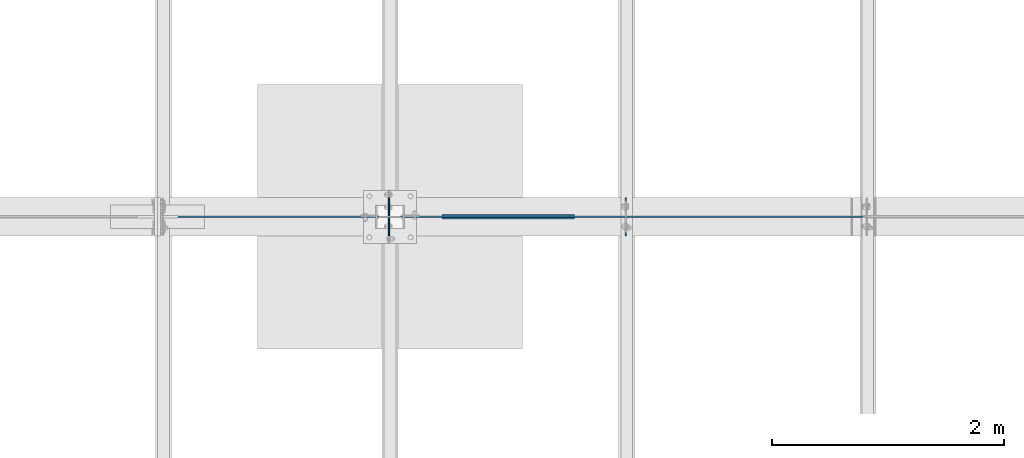
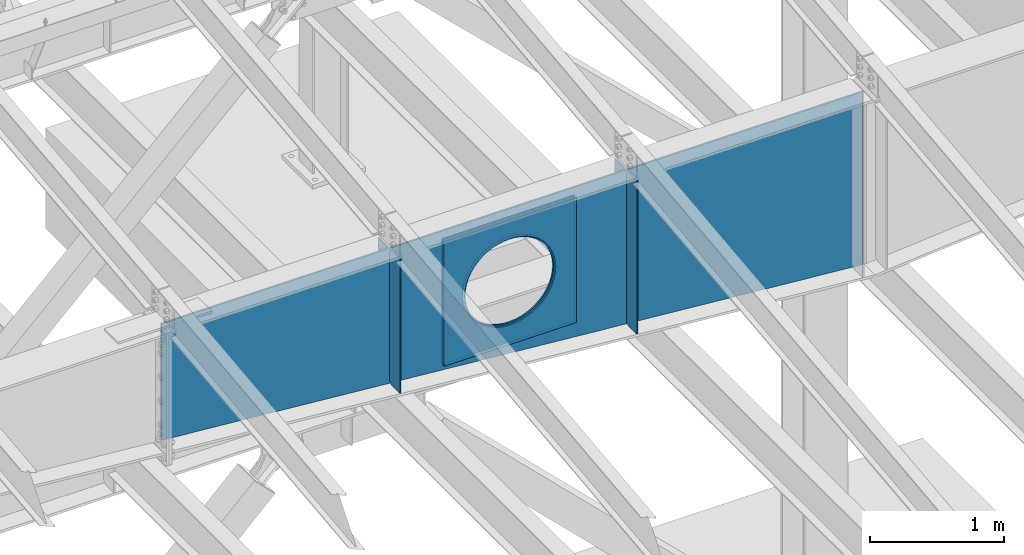
# One storey, part 972 of 1179: 7 plates, 1 element without a shape of its own.
"""IFC2X3 building model written with IfcOpenShell, lengths in millimetres."""

from ifc_helpers import new_model, si_unit, frame, origin_with_axes, place, context, subcontext, project, spatial, faceted_brep, material, type_object, element, aggregate, save


model = new_model("IFC2X3")

# Units and contexts
model_context = context("Model", 3, precision=1e-05, world=origin_with_axes())
body_context = subcontext(model_context, "Body", "Model", "MODEL_VIEW")
ifc_project = project(units=[si_unit("LENGTHUNIT", "METRE", prefix="MILLI"), si_unit("AREAUNIT", "SQUARE_METRE"), si_unit("VOLUMEUNIT", "CUBIC_METRE"), si_unit("MASSUNIT", "GRAM", prefix="KILO"), si_unit("TIMEUNIT", "SECOND"), si_unit("PLANEANGLEUNIT", "RADIAN"), si_unit("SOLIDANGLEUNIT", "STERADIAN"), si_unit("THERMODYNAMICTEMPERATUREUNIT", "DEGREE_CELSIUS"), si_unit("LUMINOUSINTENSITYUNIT", "LUMEN")], contexts=[model_context])

# Site, building, storey
site_placement = place(None, origin_with_axes())
site = spatial("IfcSite", under=ifc_project, at=site_placement, CompositionType="ELEMENT")
building_placement = place(site_placement, origin_with_axes())
building = spatial("IfcBuilding", under=site, at=building_placement, Name="Undefined", CompositionType="ELEMENT")
storey_placement = place(building_placement, origin_with_axes())
storey = spatial("IfcBuildingStorey", under=building, at=storey_placement, Name="Undefined", CompositionType="ELEMENT", Elevation=0.0)

# Assembly, plates
assembly_placement = place(storey_placement, origin_with_axes())
assembly = element("IfcElementAssembly", 1, at=assembly_placement, inside=storey, Name="RAFTER BEAM", AssemblyPlace="NOTDEFINED", PredefinedType="RIGID_FRAME")
ifc_material = material(Name="STEEL/A36")
plate_type_1 = type_object("IfcPlateType", PredefinedType="NOTDEFINED")
plate_1_placement = place(assembly_placement, frame((8272.4625, 19392.8999999624, 11103.7687496185), z_axis=(0.0, 0.0, -1.0), x_axis=(0.0, -1.0, 0.0)))
plate_1 = element("IfcPlate", 2, at=plate_1_placement, type_object=plate_type_1, material=ifc_material, Name="PLATE", context=body_context, shape_type="Brep", body=[
    faceted_brep([(0.0, -4.76249999999709, 0.0), (-2.71757744485512e-06, -4.76250000000073, 1229.06109511057), (-2.71757744485512e-06, 4.76250000000073, 1229.06109511057), (0.0, 4.76249999999709, 0.0), (131.762497663887, -4.76250000000073, 1229.06109543018), (131.762497663887, 4.76250000000073, 1229.06109543018), (157.162497338577, -4.76250000000073, 1203.66109587326), (157.162497338577, 4.76250000000073, 1203.66109587326), (157.162499942613, -4.76250000000073, 25.3999996182793), (157.162499942613, 4.76250000000073, 25.3999996182793), (131.762500381465, -4.76250000000073, -2.09183781407773e-10), (131.762500381465, 4.76250000000073, -2.09183781407773e-10)], [[[0, 1, 2, 3]], [[1, 4, 5, 2]], [[4, 6, 7, 5]], [[6, 8, 9, 7]], [[8, 10, 11, 9]], [[10, 0, 3, 11]], [[5, 7, 9, 11, 3, 2]], [[10, 8, 6, 4, 1, 0]]]),
])
plate_2_placement = place(assembly_placement, frame((10317.1625, 19392.8999999624, 11103.7687496185), z_axis=(0.0, 0.0, -1.0), x_axis=(0.0, -1.0, 0.0)))
plate_2 = element("IfcPlate", 3, at=plate_2_placement, type_object=plate_type_1, material=ifc_material, Name="PLATE", context=body_context, shape_type="Brep", body=[
    faceted_brep([(0.0, -4.76249999999709, 0.0), (-3.06581569020636e-06, -4.76250000000073, 1403.18009586334), (-3.06581569020636e-06, 4.76250000000073, 1403.18009586334), (0.0, 4.76249999999709, 0.0), (131.762497315649, -4.76250000000073, 1403.18009618295), (131.762497315649, 4.76250000000073, 1403.18009618295), (157.162496989677, -4.76250000000073, 1377.78009662603), (157.162496989677, 4.76250000000073, 1377.78009662603), (157.162499942613, -4.76250000000073, 25.3999996182793), (157.162499942613, 4.76250000000073, 25.3999996182793), (131.762500381465, -4.76250000000073, -2.09183781407773e-10), (131.762500381465, 4.76250000000073, -2.09183781407773e-10)], [[[0, 1, 2, 3]], [[1, 4, 5, 2]], [[4, 6, 7, 5]], [[6, 8, 9, 7]], [[8, 10, 11, 9]], [[10, 0, 3, 11]], [[5, 7, 9, 11, 3, 2]], [[10, 8, 6, 4, 1, 0]]]),
])
plate_3_placement = place(assembly_placement, frame((8272.4625, 19062.6999999987, 11103.7687496185), z_axis=(0.0, 0.0, -1.0), x_axis=(0.0, 1.0, 0.0)))
plate_3 = element("IfcPlate", 4, at=plate_3_placement, type_object=plate_type_1, material=ifc_material, Name="PLATE", context=body_context, shape_type="Brep", body=[
    faceted_brep([(0.0, -4.76249999999709, 0.0), (-2.71757744485512e-06, -4.76250000000073, 1229.06109511057), (-2.71757744485512e-06, 4.76250000000073, 1229.06109511057), (0.0, 4.76249999999709, 0.0), (131.762497663887, -4.76250000000073, 1229.06109543018), (131.762497663887, 4.76250000000073, 1229.06109543018), (157.162497338577, -4.76250000000073, 1203.66109587326), (157.162497338577, 4.76250000000073, 1203.66109587326), (157.162499942613, -4.76250000000073, 25.3999996182793), (157.162499942613, 4.76250000000073, 25.3999996182793), (131.762500381465, -4.76250000000073, -2.09183781407773e-10), (131.762500381465, 4.76250000000073, -2.09183781407773e-10)], [[[0, 1, 2, 3]], [[1, 4, 5, 2]], [[4, 6, 7, 5]], [[6, 8, 9, 7]], [[8, 10, 11, 9]], [[10, 0, 3, 11]], [[5, 7, 9, 11, 3, 2]], [[10, 8, 6, 4, 1, 0]]]),
])
plate_4_placement = place(assembly_placement, frame((10317.1625, 19062.6999999987, 11103.7687496185), z_axis=(0.0, 0.0, -1.0), x_axis=(0.0, 1.0, 0.0)))
plate_4 = element("IfcPlate", 5, at=plate_4_placement, type_object=plate_type_1, material=ifc_material, Name="PLATE", context=body_context, shape_type="Brep", body=[
    faceted_brep([(0.0, -4.76249999999709, 0.0), (-3.06581569020636e-06, -4.76250000000073, 1403.18009586334), (-3.06581569020636e-06, 4.76250000000073, 1403.18009586334), (0.0, 4.76249999999709, 0.0), (131.762497315649, -4.76250000000073, 1403.18009618295), (131.762497315649, 4.76250000000073, 1403.18009618295), (157.162496989677, -4.76250000000073, 1377.78009662603), (157.162496989677, 4.76250000000073, 1377.78009662603), (157.162499942613, -4.76250000000073, 25.3999996182793), (157.162499942613, 4.76250000000073, 25.3999996182793), (131.762500381465, -4.76250000000073, -2.09183781407773e-10), (131.762500381465, 4.76250000000073, -2.09183781407773e-10)], [[[0, 1, 2, 3]], [[1, 4, 5, 2]], [[4, 6, 7, 5]], [[6, 8, 9, 7]], [[8, 10, 11, 9]], [[10, 0, 3, 11]], [[5, 7, 9, 11, 3, 2]], [[10, 8, 6, 4, 1, 0]]]),
])
plate_type_2 = type_object("IfcPlateType", PredefinedType="NOTDEFINED")
plate_5_placement = place(assembly_placement, frame((9874.25, 19242.0874999987, 11016.8704879761), z_axis=(0.0, 0.0, -1.0), x_axis=(-1.0, 0.0, 0.0)))
plate_5 = element("IfcPlate", 6, at=plate_5_placement, type_object=plate_type_2, material=ifc_material, Name="PLATE", context=body_context, shape_type="Brep", body=[
    faceted_brep([(961.831841922869, -6.35000000000036, 520.111838122966), (961.831841922869, 6.35000000000036, 520.111838122966), (951.784997810006, 6.35000000000036, 469.602941943138), (951.784997810006, -6.35000000000036, 469.602941943138), (935.231371949694, 6.35000000000036, 420.837532677864), (935.231371949694, -6.35000000000036, 420.837532677864), (912.454201469933, 6.35000000000036, 374.65), (912.454201469933, -6.35000000000036, 374.65), (883.843210072659, 6.35000000000036, 331.830625399267), (883.843210072659, -6.35000000000036, 331.830625399267), (849.887939753144, 6.35000000000036, 293.112060246856), (849.887939753144, -6.35000000000036, 293.112060246856), (811.169374600733, 6.35000000000036, 259.156789927341), (811.169374600733, -6.35000000000036, 259.156789927341), (768.35, 6.35000000000036, 230.545798530067), (768.35, -6.35000000000036, 230.545798530067), (722.162467322136, 6.35000000000036, 207.768628050306), (722.162467322136, -6.35000000000036, 207.768628050306), (673.397058056862, 6.35000000000036, 191.215002189994), (673.397058056862, -6.35000000000036, 191.215002189994), (622.888161877034, 6.35000000000036, 181.168158077131), (622.888161877034, -6.35000000000036, 181.168158077131), (571.5, 6.35000000000036, 177.799999999999), (571.5, -6.35000000000036, 177.799999999999), (520.111838122966, 6.35000000000036, 181.168158077131), (520.111838122966, -6.35000000000036, 181.168158077131), (469.602941943138, 6.35000000000036, 191.215002189994), (469.602941943138, -6.35000000000036, 191.215002189994), (420.837532677864, 6.35000000000036, 207.768628050306), (420.837532677864, -6.35000000000036, 207.768628050306), (374.65, 6.35000000000036, 230.545798530067), (374.65, -6.35000000000036, 230.545798530067), (331.830625399267, 6.35000000000036, 259.156789927341), (331.830625399267, -6.35000000000036, 259.156789927341), (293.112060246856, 6.35000000000036, 293.112060246856), (293.112060246856, -6.35000000000036, 293.112060246856), (259.156789927341, 6.35000000000036, 331.830625399267), (259.156789927341, -6.35000000000036, 331.830625399267), (230.545798530067, 6.35000000000036, 374.65), (230.545798530067, -6.35000000000036, 374.65), (207.768628050306, 6.35000000000036, 420.837532677864), (207.768628050306, -6.35000000000036, 420.837532677864), (191.215002189994, 6.35000000000036, 469.602941943138), (191.215002189994, -6.35000000000036, 469.602941943138), (181.168158077131, 6.35000000000036, 520.111838122966), (181.168158077131, -6.35000000000036, 520.111838122966), (177.799999999999, 6.35000000000036, 571.5), (177.799999999999, -6.35000000000036, 571.5), (181.168158077131, 6.35000000000036, 622.888161877036), (181.168158077131, -6.35000000000036, 622.888161877036), (191.215002189994, 6.35000000000036, 673.397058056862), (191.215002189994, -6.35000000000036, 673.397058056862), (207.768628050306, 6.35000000000036, 722.162467322136), (207.768628050306, -6.35000000000036, 722.162467322136), (230.545798530067, 6.35000000000036, 768.35), (230.545798530067, -6.35000000000036, 768.35), (259.156789927341, 6.35000000000036, 811.169374600733), (259.156789927341, -6.35000000000036, 811.169374600733), (293.112060246856, 6.35000000000036, 849.887939753144), (293.112060246856, -6.35000000000036, 849.887939753144), (331.830625399267, 6.35000000000036, 883.84321007266), (331.830625399267, -6.35000000000036, 883.84321007266), (374.65, 6.35000000000036, 912.454201469933), (374.65, -6.35000000000036, 912.454201469933), (420.837532677864, 6.35000000000036, 935.231371949694), (420.837532677864, -6.35000000000036, 935.231371949694), (469.602941943138, 6.35000000000036, 951.784997810006), (469.602941943138, -6.35000000000036, 951.784997810006), (520.111838122966, 6.35000000000036, 961.831841922869), (520.111838122966, -6.35000000000036, 961.831841922869), (571.5, 6.35000000000036, 965.200000000001), (571.5, -6.35000000000036, 965.200000000001), (622.888161877034, 6.35000000000036, 961.831841922869), (622.888161877034, -6.35000000000036, 961.831841922869), (673.397058056862, 6.35000000000036, 951.784997810006), (673.397058056862, -6.35000000000036, 951.784997810006), (722.162467322136, 6.35000000000036, 935.231371949694), (722.162467322136, -6.35000000000036, 935.231371949694), (768.35, 6.35000000000036, 912.454201469933), (768.35, -6.35000000000036, 912.454201469933), (811.169374600733, 6.35000000000036, 883.843210072659), (811.169374600733, -6.35000000000036, 883.843210072659), (849.887939753144, 6.35000000000036, 849.887939753144), (849.887939753144, -6.35000000000036, 849.887939753144), (883.843210072659, 6.35000000000036, 811.169374600733), (883.843210072659, -6.35000000000036, 811.169374600733), (912.454201469933, 6.35000000000036, 768.35), (912.454201469933, -6.35000000000036, 768.35), (935.231371949694, 6.35000000000036, 722.162467322136), (935.231371949694, -6.35000000000036, 722.162467322136), (951.784997810006, 6.35000000000036, 673.397058056862), (951.784997810006, -6.35000000000036, 673.397058056862), (961.831841922869, 6.35000000000036, 622.888161877034), (961.831841922869, -6.35000000000036, 622.888161877034), (965.200000000001, 6.35000000000036, 571.5), (965.200000000001, -6.35000000000036, 571.5), (1143.0, -6.35000000000036, 0.0), (1143.0, -6.35000000000036, 1143.0), (0.0, -6.35000000000036, 1143.0), (0.0, -6.34999999999854, 0.0), (0.0, 6.34999999999854, 0.0), (1143.0, 6.35000000000036, 0.0), (1143.0, 6.35000000000036, 1143.0), (0.0, 6.35000000000036, 1143.0)], [[[0, 1, 2, 3]], [[3, 2, 4, 5]], [[5, 4, 6, 7]], [[7, 6, 8, 9]], [[9, 8, 10, 11]], [[11, 10, 12, 13]], [[13, 12, 14, 15]], [[15, 14, 16, 17]], [[17, 16, 18, 19]], [[19, 18, 20, 21]], [[21, 20, 22, 23]], [[23, 22, 24, 25]], [[25, 24, 26, 27]], [[27, 26, 28, 29]], [[29, 28, 30, 31]], [[31, 30, 32, 33]], [[33, 32, 34, 35]], [[35, 34, 36, 37]], [[37, 36, 38, 39]], [[39, 38, 40, 41]], [[41, 40, 42, 43]], [[43, 42, 44, 45]], [[45, 44, 46, 47]], [[47, 46, 48, 49]], [[49, 48, 50, 51]], [[51, 50, 52, 53]], [[53, 52, 54, 55]], [[55, 54, 56, 57]], [[57, 56, 58, 59]], [[59, 58, 60, 61]], [[61, 60, 62, 63]], [[63, 62, 64, 65]], [[65, 64, 66, 67]], [[67, 66, 68, 69]], [[69, 68, 70, 71]], [[71, 70, 72, 73]], [[73, 72, 74, 75]], [[75, 74, 76, 77]], [[77, 76, 78, 79]], [[79, 78, 80, 81]], [[81, 80, 82, 83]], [[83, 82, 84, 85]], [[85, 84, 86, 87]], [[87, 86, 88, 89]], [[89, 88, 90, 91]], [[91, 90, 92, 93]], [[93, 92, 94, 95]], [[95, 94, 1, 0]], [[96, 97, 98, 99], [3, 5, 7, 9, 11, 13, 15, 17, 19, 21, 23, 25, 27, 29, 31, 33, 35, 37, 39, 41, 43, 45, 47, 49, 51, 53, 55, 57, 59, 61, 63, 65, 67, 69, 71, 73, 75, 77, 79, 81, 83, 85, 87, 89, 91, 93, 95, 0]], [[96, 99, 100, 101]], [[97, 96, 101, 102]], [[98, 97, 102, 103]], [[99, 98, 103, 100]], [[102, 101, 100, 103], [90, 88, 86, 84, 82, 80, 78, 76, 74, 72, 70, 68, 66, 64, 62, 60, 58, 56, 54, 52, 50, 48, 46, 44, 42, 40, 38, 36, 34, 32, 30, 28, 26, 24, 22, 20, 18, 16, 14, 12, 10, 8, 6, 4, 2, 1, 94, 92]]]),
])
plate_6_placement = place(assembly_placement, frame((9874.25, 19213.5124999987, 11016.8704879761), z_axis=(0.0, 0.0, -1.0), x_axis=(-1.0, 0.0, 0.0)))
plate_6 = element("IfcPlate", 7, at=plate_6_placement, type_object=plate_type_2, material=ifc_material, Name="PLATE", context=body_context, shape_type="Brep", body=[
    faceted_brep([(961.831841922869, -6.35000000000036, 520.111838122966), (961.831841922869, 6.35000000000036, 520.111838122966), (951.784997810006, 6.35000000000036, 469.602941943138), (951.784997810006, -6.35000000000036, 469.602941943138), (935.231371949694, 6.35000000000036, 420.837532677864), (935.231371949694, -6.35000000000036, 420.837532677864), (912.454201469933, 6.35000000000036, 374.65), (912.454201469933, -6.35000000000036, 374.65), (883.843210072659, 6.35000000000036, 331.830625399267), (883.843210072659, -6.35000000000036, 331.830625399267), (849.887939753144, 6.35000000000036, 293.112060246856), (849.887939753144, -6.35000000000036, 293.112060246856), (811.169374600733, 6.35000000000036, 259.156789927341), (811.169374600733, -6.35000000000036, 259.156789927341), (768.35, 6.35000000000036, 230.545798530067), (768.35, -6.35000000000036, 230.545798530067), (722.162467322136, 6.35000000000036, 207.768628050306), (722.162467322136, -6.35000000000036, 207.768628050306), (673.397058056862, 6.35000000000036, 191.215002189994), (673.397058056862, -6.35000000000036, 191.215002189994), (622.888161877034, 6.35000000000036, 181.168158077131), (622.888161877034, -6.35000000000036, 181.168158077131), (571.5, 6.35000000000036, 177.799999999999), (571.5, -6.35000000000036, 177.799999999999), (520.111838122966, 6.35000000000036, 181.168158077131), (520.111838122966, -6.35000000000036, 181.168158077131), (469.602941943138, 6.35000000000036, 191.215002189994), (469.602941943138, -6.35000000000036, 191.215002189994), (420.837532677864, 6.35000000000036, 207.768628050306), (420.837532677864, -6.35000000000036, 207.768628050306), (374.65, 6.35000000000036, 230.545798530067), (374.65, -6.35000000000036, 230.545798530067), (331.830625399267, 6.35000000000036, 259.156789927341), (331.830625399267, -6.35000000000036, 259.156789927341), (293.112060246856, 6.35000000000036, 293.112060246856), (293.112060246856, -6.35000000000036, 293.112060246856), (259.156789927341, 6.35000000000036, 331.830625399267), (259.156789927341, -6.35000000000036, 331.830625399267), (230.545798530067, 6.35000000000036, 374.65), (230.545798530067, -6.35000000000036, 374.65), (207.768628050306, 6.35000000000036, 420.837532677864), (207.768628050306, -6.35000000000036, 420.837532677864), (191.215002189994, 6.35000000000036, 469.602941943138), (191.215002189994, -6.35000000000036, 469.602941943138), (181.168158077131, 6.35000000000036, 520.111838122966), (181.168158077131, -6.35000000000036, 520.111838122966), (177.799999999999, 6.35000000000036, 571.5), (177.799999999999, -6.35000000000036, 571.5), (181.168158077131, 6.35000000000036, 622.888161877036), (181.168158077131, -6.35000000000036, 622.888161877036), (191.215002189994, 6.35000000000036, 673.397058056862), (191.215002189994, -6.35000000000036, 673.397058056862), (207.768628050306, 6.35000000000036, 722.162467322136), (207.768628050306, -6.35000000000036, 722.162467322136), (230.545798530067, 6.35000000000036, 768.35), (230.545798530067, -6.35000000000036, 768.35), (259.156789927341, 6.35000000000036, 811.169374600733), (259.156789927341, -6.35000000000036, 811.169374600733), (293.112060246856, 6.35000000000036, 849.887939753144), (293.112060246856, -6.35000000000036, 849.887939753144), (331.830625399267, 6.35000000000036, 883.84321007266), (331.830625399267, -6.35000000000036, 883.84321007266), (374.65, 6.35000000000036, 912.454201469933), (374.65, -6.35000000000036, 912.454201469933), (420.837532677864, 6.35000000000036, 935.231371949694), (420.837532677864, -6.35000000000036, 935.231371949694), (469.602941943138, 6.35000000000036, 951.784997810006), (469.602941943138, -6.35000000000036, 951.784997810006), (520.111838122966, 6.35000000000036, 961.831841922869), (520.111838122966, -6.35000000000036, 961.831841922869), (571.5, 6.35000000000036, 965.200000000001), (571.5, -6.35000000000036, 965.200000000001), (622.888161877034, 6.35000000000036, 961.831841922869), (622.888161877034, -6.35000000000036, 961.831841922869), (673.397058056862, 6.35000000000036, 951.784997810006), (673.397058056862, -6.35000000000036, 951.784997810006), (722.162467322136, 6.35000000000036, 935.231371949694), (722.162467322136, -6.35000000000036, 935.231371949694), (768.35, 6.35000000000036, 912.454201469933), (768.35, -6.35000000000036, 912.454201469933), (811.169374600733, 6.35000000000036, 883.843210072659), (811.169374600733, -6.35000000000036, 883.843210072659), (849.887939753144, 6.35000000000036, 849.887939753144), (849.887939753144, -6.35000000000036, 849.887939753144), (883.843210072659, 6.35000000000036, 811.169374600733), (883.843210072659, -6.35000000000036, 811.169374600733), (912.454201469933, 6.35000000000036, 768.35), (912.454201469933, -6.35000000000036, 768.35), (935.231371949694, 6.35000000000036, 722.162467322136), (935.231371949694, -6.35000000000036, 722.162467322136), (951.784997810006, 6.35000000000036, 673.397058056862), (951.784997810006, -6.35000000000036, 673.397058056862), (961.831841922869, 6.35000000000036, 622.888161877034), (961.831841922869, -6.35000000000036, 622.888161877034), (965.200000000001, 6.35000000000036, 571.5), (965.200000000001, -6.35000000000036, 571.5), (1143.0, -6.35000000000036, 0.0), (1143.0, -6.35000000000036, 1143.0), (0.0, -6.35000000000036, 1143.0), (0.0, -6.34999999999854, 0.0), (0.0, 6.34999999999854, 0.0), (1143.0, 6.35000000000036, 0.0), (1143.0, 6.35000000000036, 1143.0), (0.0, 6.35000000000036, 1143.0)], [[[0, 1, 2, 3]], [[3, 2, 4, 5]], [[5, 4, 6, 7]], [[7, 6, 8, 9]], [[9, 8, 10, 11]], [[11, 10, 12, 13]], [[13, 12, 14, 15]], [[15, 14, 16, 17]], [[17, 16, 18, 19]], [[19, 18, 20, 21]], [[21, 20, 22, 23]], [[23, 22, 24, 25]], [[25, 24, 26, 27]], [[27, 26, 28, 29]], [[29, 28, 30, 31]], [[31, 30, 32, 33]], [[33, 32, 34, 35]], [[35, 34, 36, 37]], [[37, 36, 38, 39]], [[39, 38, 40, 41]], [[41, 40, 42, 43]], [[43, 42, 44, 45]], [[45, 44, 46, 47]], [[47, 46, 48, 49]], [[49, 48, 50, 51]], [[51, 50, 52, 53]], [[53, 52, 54, 55]], [[55, 54, 56, 57]], [[57, 56, 58, 59]], [[59, 58, 60, 61]], [[61, 60, 62, 63]], [[63, 62, 64, 65]], [[65, 64, 66, 67]], [[67, 66, 68, 69]], [[69, 68, 70, 71]], [[71, 70, 72, 73]], [[73, 72, 74, 75]], [[75, 74, 76, 77]], [[77, 76, 78, 79]], [[79, 78, 80, 81]], [[81, 80, 82, 83]], [[83, 82, 84, 85]], [[85, 84, 86, 87]], [[87, 86, 88, 89]], [[89, 88, 90, 91]], [[91, 90, 92, 93]], [[93, 92, 94, 95]], [[95, 94, 1, 0]], [[96, 97, 98, 99], [3, 5, 7, 9, 11, 13, 15, 17, 19, 21, 23, 25, 27, 29, 31, 33, 35, 37, 39, 41, 43, 45, 47, 49, 51, 53, 55, 57, 59, 61, 63, 65, 67, 69, 71, 73, 75, 77, 79, 81, 83, 85, 87, 89, 91, 93, 95, 0]], [[96, 99, 100, 101]], [[97, 96, 101, 102]], [[98, 97, 102, 103]], [[99, 98, 103, 100]], [[102, 101, 100, 103], [90, 88, 86, 84, 82, 80, 78, 76, 74, 72, 70, 68, 66, 64, 62, 60, 58, 56, 54, 52, 50, 48, 46, 44, 42, 40, 38, 36, 34, 32, 30, 28, 26, 24, 22, 20, 18, 16, 14, 12, 10, 8, 6, 4, 2, 1, 94, 92]]]),
])
plate_type_3 = type_object("IfcPlateType", PredefinedType="NOTDEFINED")
plate_7_placement = place(assembly_placement, frame((12369.8, 19227.7999999987, 11105.3562496185), z_axis=(0.0, 0.0, -1.0), x_axis=(-1.0, 0.0, 0.0)))
plate_7 = element("IfcPlate", 8, at=plate_7_placement, type_object=plate_type_3, material=ifc_material, Name="RAFTER BEAM", context=body_context, shape_type="Brep", body=[
    faceted_brep([(3444.79049218343, -7.9375, 610.255282406617), (3444.79049218343, 7.9375, 610.255282406617), (3435.06773981614, 7.9375, 561.375705458395), (3435.06773981614, -7.9375, 561.375705458395), (3419.0481018868, 7.9375, 514.183373911357), (3419.0481018868, -7.9375, 514.183373911357), (3397.00567884187, 7.9375, 469.485761642456), (3397.00567884187, -7.9375, 469.485761642456), (3369.31762265096, 7.9375, 428.047657190133), (3369.31762265096, -7.9375, 428.047657190133), (3336.45768363208, 7.9375, 390.578078010381), (3336.45768363208, -7.9375, 390.578078010381), (3298.98810445232, 7.9375, 357.718138991495), (3298.98810445232, -7.9375, 357.718138991495), (3257.55, 7.9375, 330.030082800586), (3257.55, -7.9375, 330.030082800586), (3212.8523877311, 7.9375, 307.987659755656), (3212.8523877311, -7.9375, 307.987659755656), (3165.66005618406, 7.9375, 291.96802182632), (3165.66005618406, -7.9375, 291.96802182632), (3116.78047923584, 7.9375, 282.245269459034), (3116.78047923584, -7.9375, 282.245269459034), (3067.05, 7.9375, 278.985761642456), (3067.05, -7.9375, 278.985761642456), (3017.31952076416, 7.9375, 282.245269459034), (3017.31952076416, -7.9375, 282.245269459034), (2968.43994381594, 7.9375, 291.96802182632), (2968.43994381594, -7.9375, 291.96802182632), (2921.2476122689, 7.9375, 307.987659755656), (2921.2476122689, -7.9375, 307.987659755656), (2876.55, 7.9375, 330.030082800586), (2876.55, -7.9375, 330.030082800586), (2835.11189554768, 7.9375, 357.718138991495), (2835.11189554768, -7.9375, 357.718138991495), (2797.64231636793, 7.9375, 390.578078010381), (2797.64231636793, -7.9375, 390.578078010381), (2764.78237734904, 7.9375, 428.047657190133), (2764.78237734904, -7.9375, 428.047657190133), (2737.09432115813, 7.9375, 469.485761642456), (2737.09432115813, -7.9375, 469.485761642456), (2715.0518981132, 7.9375, 514.183373911357), (2715.0518981132, -7.9375, 514.183373911357), (2699.03226018387, 7.9375, 561.375705458395), (2699.03226018387, -7.9375, 561.375705458395), (2689.30950781658, 7.9375, 610.255282406617), (2689.30950781658, -7.9375, 610.255282406617), (2686.05, 7.9375, 659.985761642456), (2686.05, -7.9375, 659.985761642456), (2689.30950781658, 7.9375, 709.716240878297), (2689.30950781658, -7.9375, 709.716240878297), (2699.03226018387, 7.9375, 758.595817826517), (2699.03226018387, -7.9375, 758.595817826517), (2715.0518981132, 7.9375, 805.788149373555), (2715.0518981132, -7.9375, 805.788149373555), (2737.09432115813, 7.9375, 850.485761642456), (2737.09432115813, -7.9375, 850.485761642456), (2764.78237734904, 7.9375, 891.923866094779), (2764.78237734904, -7.9375, 891.923866094779), (2797.64231636793, 7.9375, 929.393445274531), (2797.64231636793, -7.9375, 929.393445274531), (2835.11189554768, 7.9375, 962.253384293417), (2835.11189554768, -7.9375, 962.253384293417), (2876.55, 7.9375, 989.941440484326), (2876.55, -7.9375, 989.941440484326), (2921.2476122689, 7.9375, 1011.98386352926), (2921.2476122689, -7.9375, 1011.98386352926), (2968.43994381594, 7.9375, 1028.00350145859), (2968.43994381594, -7.9375, 1028.00350145859), (3017.31952076416, 7.9375, 1037.72625382588), (3017.31952076416, -7.9375, 1037.72625382588), (3067.05, 7.9375, 1040.98576164246), (3067.05, -7.9375, 1040.98576164246), (3116.78047923584, 7.9375, 1037.72625382588), (3116.78047923584, -7.9375, 1037.72625382588), (3165.66005618406, 7.9375, 1028.00350145859), (3165.66005618406, -7.9375, 1028.00350145859), (3212.8523877311, 7.9375, 1011.98386352926), (3212.8523877311, -7.9375, 1011.98386352926), (3257.55, 7.9375, 989.941440484326), (3257.55, -7.9375, 989.941440484326), (3298.98810445232, 7.9375, 962.253384293417), (3298.98810445232, -7.9375, 962.253384293417), (3336.45768363208, 7.9375, 929.393445274531), (3336.45768363208, -7.9375, 929.393445274531), (3369.31762265096, 7.9375, 891.923866094778), (3369.31762265096, -7.9375, 891.923866094778), (3397.00567884187, 7.9375, 850.485761642456), (3397.00567884187, -7.9375, 850.485761642456), (3419.0481018868, 7.9375, 805.788149373555), (3419.0481018868, -7.9375, 805.788149373555), (3435.06773981614, 7.9375, 758.595817826515), (3435.06773981614, -7.9375, 758.595817826515), (3444.79049218343, 7.9375, 709.716240878295), (3444.79049218343, -7.9375, 709.716240878295), (3448.05, 7.9375, 659.985761642456), (3448.05, -7.9375, 659.985761642456), (0.0, 7.9375, 1581.15002441406), (15.875, -7.9375, 1579.79816881816), (6070.59999545302, -7.9375, 1064.20044492659), (6070.59999545302, 7.9375, 1064.20044492659), (0.0, 7.9375, 0.0), (15.875, -7.9375, 0.0), (6070.59999545302, 7.9375, 0.0), (6070.59999545302, -7.9375, 0.0)], [[[0, 1, 2, 3]], [[3, 2, 4, 5]], [[5, 4, 6, 7]], [[7, 6, 8, 9]], [[9, 8, 10, 11]], [[11, 10, 12, 13]], [[13, 12, 14, 15]], [[15, 14, 16, 17]], [[17, 16, 18, 19]], [[19, 18, 20, 21]], [[21, 20, 22, 23]], [[23, 22, 24, 25]], [[25, 24, 26, 27]], [[27, 26, 28, 29]], [[29, 28, 30, 31]], [[31, 30, 32, 33]], [[33, 32, 34, 35]], [[35, 34, 36, 37]], [[37, 36, 38, 39]], [[39, 38, 40, 41]], [[41, 40, 42, 43]], [[43, 42, 44, 45]], [[45, 44, 46, 47]], [[47, 46, 48, 49]], [[49, 48, 50, 51]], [[51, 50, 52, 53]], [[53, 52, 54, 55]], [[55, 54, 56, 57]], [[57, 56, 58, 59]], [[59, 58, 60, 61]], [[61, 60, 62, 63]], [[63, 62, 64, 65]], [[65, 64, 66, 67]], [[67, 66, 68, 69]], [[69, 68, 70, 71]], [[71, 70, 72, 73]], [[73, 72, 74, 75]], [[75, 74, 76, 77]], [[77, 76, 78, 79]], [[79, 78, 80, 81]], [[81, 80, 82, 83]], [[83, 82, 84, 85]], [[85, 84, 86, 87]], [[87, 86, 88, 89]], [[89, 88, 90, 91]], [[91, 90, 92, 93]], [[93, 92, 94, 95]], [[95, 94, 1, 0]], [[96, 97, 98, 99]], [[97, 96, 100, 101]], [[101, 100, 102, 103]], [[97, 101, 103, 98], [3, 5, 7, 9, 11, 13, 15, 17, 19, 21, 23, 25, 27, 29, 31, 33, 35, 37, 39, 41, 43, 45, 47, 49, 51, 53, 55, 57, 59, 61, 63, 65, 67, 69, 71, 73, 75, 77, 79, 81, 83, 85, 87, 89, 91, 93, 95, 0]], [[102, 99, 98, 103]], [[100, 96, 99, 102], [90, 88, 86, 84, 82, 80, 78, 76, 74, 72, 70, 68, 66, 64, 62, 60, 58, 56, 54, 52, 50, 48, 46, 44, 42, 40, 38, 36, 34, 32, 30, 28, 26, 24, 22, 20, 18, 16, 14, 12, 10, 8, 6, 4, 2, 1, 94, 92]]]),
])
aggregate(assembly, [plate_1, plate_2, plate_3, plate_4, plate_5, plate_6, plate_7])

save(model, "model.ifc")
